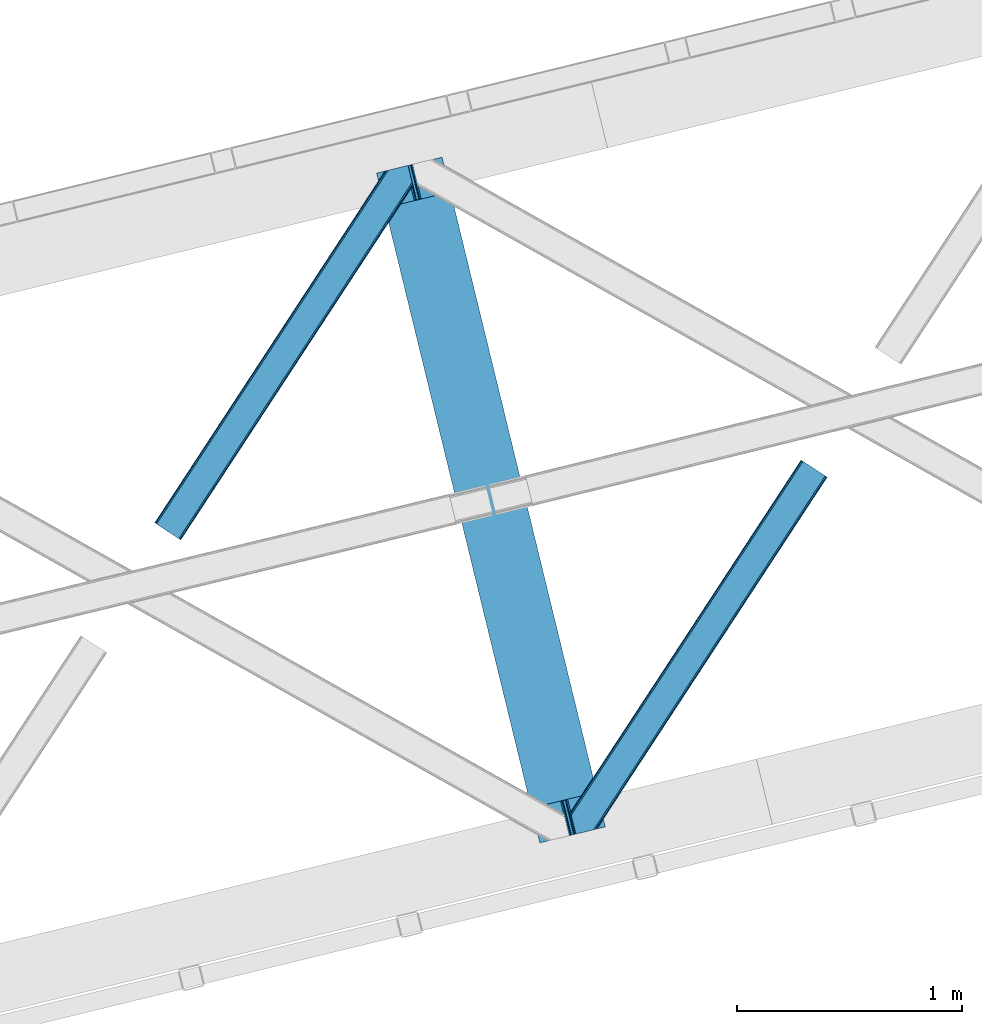
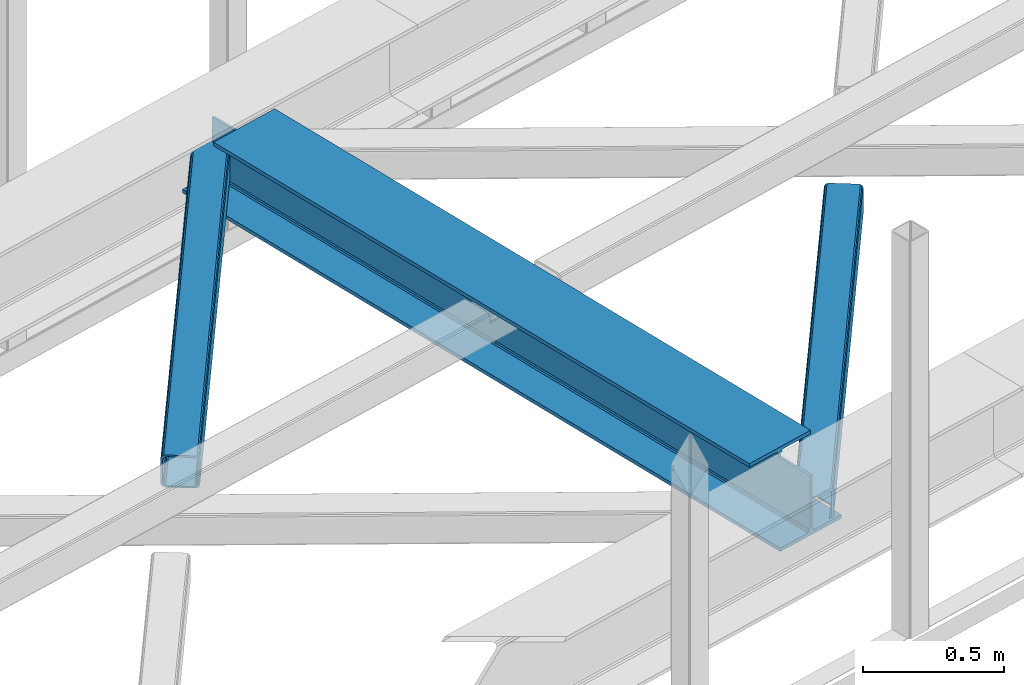
# One storey, part 29 of 67: 2 members, 1 beam.
"""IFC4 building model written with IfcOpenShell, lengths in millimetres."""

from ifc_helpers import new_model, entity, si_unit, converted_unit, derived_unit, direction, frame, origin, place, context, subcontext, project, spatial, triangles, polygons, material, type_object, element, save


model = new_model("IFC4")

# Units and contexts
model_context = context("Model", 3, precision=0.01, world=origin(), true_north=direction((6.12303176911189e-17, 1.0)))
plan_context = context("Plan", 3, precision=0.01, world=origin(), true_north=direction((6.12303176911189e-17, 1.0)))
body_context = subcontext(model_context, "Body", "Model", "MODEL_VIEW")
ifc_project = project(units=[si_unit("LENGTHUNIT", "METRE", prefix="MILLI"), si_unit("AREAUNIT", "SQUARE_METRE"), si_unit("VOLUMEUNIT", "CUBIC_METRE"), converted_unit("PLANEANGLEUNIT", "DEGREE", entity("IfcRatioMeasure", 0.0174532925199433), si_unit("PLANEANGLEUNIT", "RADIAN"), dimensions=[0, 0, 0, 0, 0, 0, 0]), si_unit("MASSUNIT", "GRAM", prefix="KILO"), derived_unit("MASSDENSITYUNIT", [(si_unit("MASSUNIT", "GRAM", prefix="KILO"), 1), (si_unit("LENGTHUNIT", "METRE"), -3)]), derived_unit("MOMENTOFINERTIAUNIT", [(si_unit("LENGTHUNIT", "METRE"), 4)]), si_unit("TIMEUNIT", "SECOND"), si_unit("FREQUENCYUNIT", "HERTZ"), si_unit("THERMODYNAMICTEMPERATUREUNIT", "DEGREE_CELSIUS"), derived_unit("THERMALTRANSMITTANCEUNIT", [(si_unit("MASSUNIT", "GRAM", prefix="KILO"), 1), (si_unit("THERMODYNAMICTEMPERATUREUNIT", "KELVIN"), -1), (si_unit("TIMEUNIT", "SECOND"), -3)]), derived_unit("VOLUMETRICFLOWRATEUNIT", [(si_unit("LENGTHUNIT", "METRE"), 3), (si_unit("TIMEUNIT", "SECOND"), -1)]), derived_unit("MASSFLOWRATEUNIT", [(si_unit("MASSUNIT", "GRAM", prefix="KILO"), 1), (si_unit("TIMEUNIT", "SECOND"), -1)]), derived_unit("ROTATIONALFREQUENCYUNIT", [(si_unit("TIMEUNIT", "SECOND"), -1)]), si_unit("ELECTRICCURRENTUNIT", "AMPERE"), si_unit("ELECTRICVOLTAGEUNIT", "VOLT"), si_unit("POWERUNIT", "WATT"), si_unit("FORCEUNIT", "NEWTON", prefix="KILO"), si_unit("ILLUMINANCEUNIT", "LUX"), si_unit("LUMINOUSFLUXUNIT", "LUMEN"), si_unit("LUMINOUSINTENSITYUNIT", "CANDELA"), derived_unit("USERDEFINED", [(si_unit("MASSUNIT", "GRAM", prefix="KILO"), -1), (si_unit("LENGTHUNIT", "METRE"), -2), (si_unit("TIMEUNIT", "SECOND"), 3), (si_unit("LUMINOUSFLUXUNIT", "LUMEN"), 1)]), derived_unit("LINEARVELOCITYUNIT", [(si_unit("LENGTHUNIT", "METRE"), 1), (si_unit("TIMEUNIT", "SECOND"), -1)]), si_unit("PRESSUREUNIT", "PASCAL"), derived_unit("USERDEFINED", [(si_unit("LENGTHUNIT", "METRE"), -2), (si_unit("MASSUNIT", "GRAM", prefix="KILO"), 1), (si_unit("TIMEUNIT", "SECOND"), -2)]), derived_unit("LINEARFORCEUNIT", [(si_unit("MASSUNIT", "GRAM", prefix="KILO"), 1), (si_unit("LENGTHUNIT", "METRE"), 1), (si_unit("TIMEUNIT", "SECOND"), -2), (si_unit("LENGTHUNIT", "METRE"), -1)]), derived_unit("PLANARFORCEUNIT", [(si_unit("MASSUNIT", "GRAM", prefix="KILO"), 1), (si_unit("LENGTHUNIT", "METRE"), 1), (si_unit("TIMEUNIT", "SECOND"), -2), (si_unit("LENGTHUNIT", "METRE"), -2)])], contexts=[model_context, plan_context])

# Site, building, storey
site_placement = place(None, origin())
site = spatial("IfcSite", under=ifc_project, at=site_placement, CompositionType="ELEMENT")
building_placement = place(site_placement, origin())
building = spatial("IfcBuilding", under=site, at=building_placement, CompositionType="ELEMENT")
storey_placement = place(building_placement, frame((0.0, 0.0, 19800.0)))
storey = spatial("IfcBuildingStorey", under=building, at=storey_placement, CompositionType="ELEMENT", Elevation=19800.0)

# Beam
ifc_material = material(Name="Metal painted (White)")
beam_type = type_object("IfcBeamType", PredefinedType="BEAM")
beam_placement = place(storey_placement, frame((-43080.9339433779, 7293.4957766484, 3808.0)))
element("IfcBeam", 1, at=beam_placement, inside=storey, type_object=beam_type, material=ifc_material, ObjectType="Steel Beam", PredefinedType="BEAM", context=body_context, shape_type="Tessellation", body=[
    polygons([(1018.1664837833, 71.047827897101, 15.5000000000051), (1018.1664837833, 71.0478278971021, 0.0), (291.465617442446, 3052.25531830421, 0.0), (291.465617442455, 3052.25531830421, 15.5000000000051), (894.779372399338, 40.9709140873291, 15.5000000000051), (168.078506058482, 3022.17840449444, 15.5000000000051), (888.087028625366, 39.3395844888243, 16.8701684148028), (161.38616228452, 3020.54707489594, 16.8701684148028), (882.413533524751, 37.956610033653, 20.7720779386478), (155.712667183904, 3019.16410044076, 20.7720779386478), (878.622625296176, 37.0325360459184, 26.6116982174338), (151.921758955329, 3018.24002645303, 26.6116982174338), (877.291435352788, 36.7080444135018, 33.500000000001), (150.590569011924, 3017.91553482062, 33.500000000001), (140.875048430514, 3015.54727389071, 33.500000000001), (140.875048430522, 3015.54727389071, 259.000000000006), (150.590569011924, 3017.91553482061, 259.000000000006), (0.0, 2981.20749040711, 4.33146851719357e-12), (0.0, 2981.20749040711, 15.5000000000051), (123.387111383972, 3011.28440421688, 15.5000000000051), (130.079455157918, 3012.91573381539, 16.8701684148028), (135.752950258542, 3014.29870827056, 20.7720779386478), (139.543858487117, 3015.2227822583, 26.6116982174338), (877.291435352779, 36.7080444135018, 259.000000000006), (867.575914771369, 34.3397834835981, 259.000000000006), (867.575914771369, 34.3397834835981, 33.500000000001), (866.244724827972, 34.0152918511837, 26.6116982174338), (862.453816599406, 33.0912178634492, 20.7720779386478), (856.780321498782, 31.7082434082778, 16.8701684148028), (850.087977724819, 30.076913809773, 15.5000000000051), (726.700866340864, 0.0, 15.5000000000051), (726.700866340864, 0.0, 4.33146851719357e-12), (839.723099725414, 190.827961666225, 259.069792599954), (188.068298227647, 2864.16742161973, 259.000000000006), (188.291691329497, 2863.25097721476, 259.617303331129), (188.304080173122, 2863.20015298098, 266.500003008253), (839.577920935824, 191.42343960925, 266.500002998871), (839.578271056576, 191.422003304514, 260.000004007593), (830.098162489501, 188.087889491627, 259.00634317046), (829.874792453805, 189.004341089457, 259.617303331129), (829.862403610162, 189.055165323231, 266.500003008253), (178.588562847469, 2860.83187869496, 266.500002998871), (178.588212726717, 2860.8333149997, 260.000004007593), (178.443407068381, 2861.42736381349, 259.076120467494), (178.352777646246, 2861.79916068982, 259.000000000006), (840.90940880576, 191.746709053936, 273.388305639792), (844.699685394447, 192.673374225849, 279.227924098781), (850.372756341985, 194.058088689525, 283.129832400619), (857.06494802311, 195.690042220338, 284.500000377228), (980.451976710954, 225.76729527545, 284.500000138975), (980.450306904303, 225.774145344181, 299.999995328161), (688.984884807032, 154.725516080139, 299.999995890966), (688.986554613693, 154.718666011408, 284.500000701776), (812.373583301528, 184.795919066518, 284.500000463524), (819.066070197675, 186.426661533098, 283.129832461069), (824.739981846427, 187.807927177623, 279.227924137327), (828.531516633419, 188.72943082692, 273.388305663689), (177.257074977551, 2860.50860925028, 273.388305639792), (173.466798388846, 2859.58194407836, 279.227924098781), (167.793727441316, 2858.19722961469, 283.129832400619), (161.101535760182, 2856.56527608387, 284.500000377228), (37.7145070723471, 2826.48802302876, 284.500000138975), (37.7161768789988, 2826.48117296003, 299.999995328161), (329.181598976269, 2897.52980222407, 299.999995890962), (329.179929169617, 2897.5366522928, 284.500000701776), (205.792900481765, 2867.45939923769, 284.500000463524), (199.100413585626, 2865.82865677111, 283.129832461069), (193.426501936866, 2864.44739112659, 279.227924137327), (189.634967149874, 2863.52588747729, 273.388305663689)], [[[1, 2, 3, 4]], [[5, 1, 4, 6]], [[7, 5, 6, 8]], [[9, 7, 8, 10]], [[11, 9, 10, 12]], [[13, 11, 12, 14]], [[15, 16, 17, 14, 12, 10, 8, 6, 4, 3, 18, 19, 20, 21, 22, 23]], [[13, 24, 25, 26, 27, 28, 29, 30, 31, 32, 2, 1, 5, 7, 9, 11]], [[2, 32, 18, 3]], [[32, 31, 19, 18]], [[31, 30, 20, 19]], [[27, 26, 15, 23]], [[28, 27, 23, 22]], [[29, 28, 22, 21]], [[30, 29, 21, 20]], [[33, 24, 13, 14, 17, 34, 35, 36, 37, 38]], [[25, 39, 40, 41, 42, 43, 44, 16, 15, 26]], [[39, 25, 24, 33]], [[45, 34, 17, 16]], [[41, 40, 38, 37, 46, 47, 48, 49, 50, 51, 52, 53, 54, 55, 56, 57]], [[42, 58, 59, 60, 61, 62, 63, 64, 65, 66, 67, 68, 69, 36, 35, 43]], [[46, 37, 36, 69]], [[47, 46, 69, 68]], [[48, 47, 68, 67]], [[49, 48, 67, 66]], [[50, 49, 66, 65]], [[51, 50, 65, 64]], [[52, 51, 64, 63]], [[53, 52, 63, 62]], [[54, 53, 62, 61]], [[55, 54, 61, 60]], [[56, 55, 60, 59]], [[57, 56, 59, 58]], [[41, 57, 58, 42]]], closed=False),
])

# Members
member_type_1 = type_object("IfcMemberType", PredefinedType="BRACE")
member_1_placement = place(storey_placement, frame((-44069.1426269531, 8641.4992767334, 3823.99987792968)))
element("IfcMember", 2, at=member_1_placement, inside=storey, type_object=member_type_1, ObjectType="Steel Horizontal Brace", PredefinedType="BRACE", context=body_context, shape_type="Tessellation", body=[
    triangles([(994.771838378911, 1564.02662658691, 0.0), (1028.82092285156, 1424.34794311523, 0.0), (14.6409667968765, 67.1040435791019, 0.0), (102.486767578128, 9.58604278564417, 0.0), (1.1162109375, 75.9604797363281, 10.8039916992202), (0.0, 76.6900863647461, 17.5012573242202), (1025.02580566407, 1642.17883300781, 17.5012573242202), (4.28811035156832, 73.8821182250977, 5.12526855468968), (990.474426269531, 1585.8776184082, 9.49942016601563), (990.041894531256, 1584.44747314453, 8.74132690429906), (989.90701904297, 1583.99168701172, 8.49948120117188), (990.758129882815, 1580.48841247559, 5.12526855468968), (1027.30938720703, 1642.73461303711, 10.8691040039084), (1027.77912597657, 1642.84972229004, 9.49942016601563), (992.599877929693, 1572.93538513184, 1.33247680664135), (9.03665771484521, 70.7724243164066, 1.33247680664135), (1025.02580566407, 1642.17883300781, 122.499499511719), (0.0, 76.6900863647461, 122.499499511719), (1026.92336425782, 1642.64043273926, 129.196765136719), (1.1162109375, 75.9604797363281, 129.196765136719), (1032.31838378907, 1643.95546875, 134.87548828125), (4.28811035156832, 73.8821182250977, 134.87548828125), (1040.39230957031, 1645.92395324707, 138.668280029298), (9.03665771484521, 70.7724243164066, 138.668280029298), (1049.91730957032, 1648.24590454102, 140.00075683594), (14.6409667968765, 67.1040435791019, 140.00075683594), (994.869506835938, 1567.85081176758, 9.49942016601563), (994.75788574219, 1567.00667724609, 9.2947814941399), (994.650915527345, 1566.15091552734, 9.08781738281323), (994.539294433598, 1565.30561828613, 8.8831787109375), (994.74393310547, 1564.14522399902, 8.49948120117188), (1047.05236816406, 1647.54827270508, 9.49942016601563), (14.8921142578183, 66.9377746582031, 8.3320495605476), (20.4964233398496, 63.2693939208984, 6.99957275390625), (997.041467285162, 1554.71440429688, 6.99957275390625), (10.1435668945342, 70.0480499267578, 12.1248413085959), (1042.27126464844, 1646.38322753906, 12.1248413085959), (1036.87624511719, 1645.06702880859, 17.8035644531265), (1034.98333740234, 1644.60542907715, 24.5008300781265), (6.97166748047312, 72.1258300781246, 17.8035644531265), (5.85545654297312, 72.8554367065426, 24.5008300781265), (1026.55129394532, 1433.65900268555, 6.99957275390625), (96.6266601562529, 13.4206924438477, 6.99957275390625), (1028.71860351563, 1424.77698669434, 8.41343994140698), (1032.83463134766, 1407.88615722656, 5.12526855468968), (1033.6857421875, 1404.3817199707, 8.49948120117188), (1030.99288330079, 1415.43918457031, 1.33247680664135), (1034.98333740234, 1644.60542907715, 115.499926757813), (5.85545654297312, 72.8554367065426, 115.499926757813), (1050.3498413086, 1648.35171203613, 131.668707275392), (1059.8748413086, 1650.67250061035, 133.001184082033), (20.4964233398496, 63.2693939208984, 133.001184082033), (14.8921142578183, 66.9377746582031, 131.668707275392), (1042.27126464844, 1646.38322753906, 127.873590087893), (10.1435668945342, 70.0480499267578, 127.873590087893), (1036.87624511719, 1645.06702880859, 122.197192382813), (6.97166748047312, 72.1258300781246, 122.197192382813), (1128.10788574219, 1667.30520629883, 140.00075683594), (1128.10788574219, 1667.30520629883, 133.001184082033), (1144.33015136719, 1600.75810546875, 140.00075683594), (102.486767578128, 9.58604278564417, 140.00075683594), (1142.06052246094, 1610.07032775879, 133.001184082033), (96.6266601562529, 13.4206924438477, 133.001184082033), (1146.50211181641, 1591.84934692383, 138.668280029298), (108.08642578125, 5.91766204833948, 138.668280029298), (1148.33920898438, 1584.29631958008, 134.87548828125), (112.834973144534, 2.80738677978479, 134.87548828125), (1149.57169189453, 1579.2501159668, 129.196765136719), (116.011523437504, 0.729606628417969, 129.196765136719), (1150.00422363282, 1577.47813110351, 122.499499511719), (117.127734375004, 0.0, 122.499499511719), (1150.00422363282, 1577.47813110351, 17.5012573242202), (117.127734375004, 0.0, 17.5012573242202), (106.979516601568, 6.64203643798828, 127.873590087893), (110.156066894531, 4.56425628662146, 122.197192382813), (111.267626953129, 3.83406829833984, 115.499926757813), (102.230969238284, 9.75231170654297, 131.668707275392), (116.011523437504, 0.729606628417969, 10.8039916992202), (106.979516601568, 6.64203643798828, 12.1248413085959), (112.834973144534, 2.80738677978479, 5.12526855468968), (111.267626953129, 3.83406829833984, 24.5008300781265), (110.156066894531, 4.56425628662146, 17.8035644531265), (108.08642578125, 5.91766204833948, 1.33247680664135), (102.230969238284, 9.75231170654297, 8.3320495605476), (1147.30206298828, 1588.56233825684, 122.197192382813), (1147.73459472656, 1586.79035339356, 115.499926757813), (1146.06958007813, 1593.60854187012, 127.873590087893), (1144.23248291016, 1601.16040649414, 131.668707275392), (1147.73459472656, 1586.79035339356, 24.5008300781265), (1147.21369628907, 1588.9239440918, 17.8686767578147), (1149.994921875, 1577.51650085449, 16.5013183593765), (1147.10672607422, 1589.36461486816, 16.5013183593765), (1145.27427978516, 1573.10863037109, 10.8714294433594), (1034.62056884766, 1404.788671875, 9.49942016601563), (1144.12551269532, 1572.03427734375, 9.49942016601563), (1142.79071044922, 1588.59721984863, 12.1248413085959), (1030.22548828126, 1422.8143157959, 9.49942016601563), (1029.19764404297, 1423.6724029541, 8.80643920898365), (1139.73043212891, 1590.05992126465, 9.49942016601563)], [[1, 2, 3], [4, 3, 2], [5, 6, 7], [8, 9, 10], [11, 12, 8], [5, 13, 9], [9, 8, 5], [13, 14, 9], [15, 1, 16], [3, 16, 1], [12, 15, 8], [16, 8, 15], [7, 13, 5], [17, 7, 6], [6, 18, 17], [19, 17, 20], [18, 20, 17], [21, 19, 22], [20, 22, 19], [23, 21, 24], [22, 24, 21], [25, 23, 26], [24, 26, 23], [27, 28, 9], [28, 29, 10], [29, 30, 10], [30, 31, 11], [14, 32, 27], [27, 9, 14], [33, 34, 35], [36, 33, 31], [31, 30, 36], [28, 36, 29], [28, 27, 36], [36, 30, 29], [32, 37, 27], [36, 27, 37], [35, 31, 33], [38, 39, 40], [41, 40, 39], [37, 38, 36], [40, 36, 38], [42, 35, 34], [34, 43, 42], [1, 35, 42], [31, 12, 11], [1, 31, 35], [31, 15, 12], [31, 1, 15], [2, 1, 42], [44, 2, 42], [45, 44, 46], [44, 47, 2], [44, 45, 47], [39, 48, 41], [49, 41, 48], [50, 51, 52], [52, 53, 50], [54, 50, 53], [53, 55, 54], [56, 54, 55], [55, 57, 56], [48, 56, 57], [57, 49, 48], [56, 17, 19], [50, 23, 25], [58, 51, 25], [51, 58, 59], [51, 50, 25], [54, 23, 50], [54, 56, 21], [21, 23, 54], [19, 21, 56], [39, 7, 17], [37, 14, 38], [56, 48, 17], [37, 32, 14], [39, 38, 7], [48, 39, 17], [13, 7, 38], [38, 14, 13], [60, 25, 61], [25, 60, 58], [26, 61, 25], [51, 62, 63], [51, 59, 62], [63, 52, 51], [64, 60, 61], [61, 65, 64], [66, 64, 65], [65, 67, 66], [68, 66, 67], [67, 69, 68], [70, 68, 69], [69, 71, 70], [72, 70, 71], [71, 73, 72], [69, 74, 75], [76, 73, 71], [69, 75, 71], [69, 67, 74], [75, 76, 71], [74, 67, 65], [63, 61, 26], [61, 77, 65], [77, 61, 63], [77, 74, 65], [78, 79, 80], [81, 73, 76], [73, 82, 78], [82, 73, 81], [78, 82, 79], [4, 43, 3], [83, 80, 79], [79, 84, 83], [84, 43, 4], [4, 83, 84], [55, 24, 22], [26, 52, 63], [26, 53, 52], [53, 26, 24], [55, 53, 24], [49, 18, 6], [20, 57, 55], [22, 20, 55], [57, 20, 18], [49, 57, 18], [16, 36, 8], [3, 43, 34], [34, 33, 3], [33, 36, 16], [16, 3, 33], [5, 8, 36], [6, 41, 49], [40, 6, 5], [6, 40, 41], [40, 5, 36], [85, 86, 75], [76, 75, 86], [87, 85, 74], [75, 74, 85], [88, 87, 77], [74, 77, 87], [62, 88, 63], [77, 63, 88], [86, 89, 76], [81, 76, 89], [90, 91, 92], [70, 72, 89], [72, 90, 89], [89, 86, 70], [72, 91, 90], [85, 70, 86], [68, 70, 85], [66, 85, 87], [85, 66, 68], [87, 64, 66], [88, 64, 87], [88, 62, 60], [88, 60, 64], [62, 58, 60], [62, 59, 58], [73, 78, 93], [93, 72, 73], [94, 93, 78], [94, 95, 93], [80, 45, 46], [46, 78, 80], [46, 94, 78], [47, 45, 83], [80, 83, 45], [2, 47, 4], [83, 4, 47], [93, 91, 72], [82, 81, 89], [82, 92, 96], [82, 90, 92], [84, 97, 98], [79, 96, 97], [97, 84, 79], [96, 99, 97], [43, 84, 44], [44, 42, 43], [96, 79, 82], [89, 90, 82], [96, 91, 93], [96, 92, 91], [96, 95, 99], [93, 95, 96], [99, 95, 97], [94, 97, 95]]),
])
member_type_2 = type_object("IfcMemberType", PredefinedType="BRACE")
member_2_placement = place(storey_placement, frame((-42217.8230712891, 7332.57045135498, 3823.99987792968)))
element("IfcMember", 3, at=member_2_placement, inside=storey, type_object=member_type_2, ObjectType="Steel Horizontal Brace", PredefinedType="BRACE", context=body_context, shape_type="Tessellation", body=[
    triangles([(109.770043945311, 259.950411987305, 7.52047119140843), (115.034838867192, 238.366264343262, 7.77626953125218), (114.220935058598, 239.947563171387, 8.3320495605476), (108.811962890628, 259.663220214844, 8.52041015625218), (113.639575195317, 239.860359191895, 8.52041015625218), (112.211755371092, 237.678515625, 8.52041015625218), (91.0363037109419, 232.517202758789, 8.52041015625218), (109.537499999999, 237.026229858398, 9.49942016601563), (90.2642578125015, 232.328842163086, 9.49942016601563), (5.02294921875, 77.405158996582, 9.49942016601563), (0.62786865234375, 95.4313842773436, 9.49942016601563), (1046.62448730469, 1651.75382995605, 6.99957275390625), (1041.02482910157, 1655.42279205322, 8.3320495605476), (116.704504394533, 231.514938354492, 6.99957275390625), (1036.27163085937, 1658.53248596191, 12.1248413085959), (3.93464355469041, 81.8758163452148, 12.1248413085959), (1033.09973144531, 1660.61084747314, 17.8035644531265), (2.70216064453416, 86.9220199584961, 17.8035644531265), (1031.98352050781, 1661.3398727417, 24.5008300781265), (2.26962890625146, 88.6945861816403, 24.5008300781265), (1122.759375, 1601.905128479, 6.99957275390625), (146.20968017578, 110.459536743164, 6.99957275390625), (1031.98352050781, 1661.3398727417, 115.499926757813), (2.26962890625146, 88.6945861816403, 115.499926757813), (1033.09973144531, 1660.61084747314, 122.197192382813), (2.70216064453416, 86.9220199584961, 122.197192382813), (1036.27163085937, 1658.53248596191, 127.873590087893), (3.93464355469041, 81.8758163452148, 127.873590087893), (1041.02482910157, 1655.42279205322, 131.668707275392), (5.77174072265916, 74.3233703613278, 131.668707275392), (1046.62448730469, 1651.75382995605, 133.001184082033), (7.94370117187646, 65.4146118164063, 133.001184082033), (1027.24427490235, 1664.44491577148, 10.8039916992202), (0.520898437498545, 95.8720550537109, 10.8691040039084), (0.0, 98.0062271118168, 17.5012573242202), (1035.16472167969, 1659.25686035156, 1.33247680664135), (112.262915039064, 249.735919189453, 1.33247680664135), (110.546740722661, 256.77269897461, 5.59500732422021), (109.077062988283, 259.839953613281, 8.32042236328198), (1030.41617431641, 1662.36713562012, 5.12526855468968), (1040.76903076172, 1655.58847961426, 0.0), (114.434875488281, 240.827160644531, 0.0), (1026.12806396485, 1665.1745223999, 17.5012573242202), (1128.61483154297, 1598.07106018066, 0.0), (148.479309082031, 101.147895812988, 0.0), (150.651269531249, 92.2391372680668, 1.33247680664135), (148.511865234374, 101.029879760742, 8.49948120117188), (152.493017578126, 84.6866912841797, 5.12526855468968), (153.348779296874, 81.1828353881838, 8.49948120117188), (1026.12806396485, 1665.1745223999, 122.499499511719), (0.0, 98.0062271118168, 122.499499511719), (1040.76903076172, 1655.58847961426, 140.00075683594), (1035.16472167969, 1659.25686035156, 138.668280029298), (3.50211181640771, 83.6350112915043, 138.668280029298), (5.674072265625, 74.7262527465818, 140.00075683594), (1030.41617431641, 1662.36713562012, 134.87548828125), (1.66501464843896, 91.1874572753904, 134.87548828125), (1027.24427490235, 1664.44491577148, 129.196765136719), (0.432531738282705, 96.2342422485353, 129.196765136719), (23.8915649414048, 0.0, 140.00075683594), (23.8915649414048, 0.0, 133.001184082033), (1128.61483154297, 1598.07106018066, 140.00075683594), (93.3384887695356, 16.9286178588864, 140.00075683594), (1122.759375, 1601.905128479, 133.001184082033), (83.3809570312515, 14.5014404296871, 133.001184082033), (1143.25579833984, 1588.48443603516, 122.499499511719), (1142.13958740234, 1589.21404266357, 129.196765136719), (118.225341796875, 22.9956893920898, 122.499499511719), (116.332434082033, 22.5340896606449, 129.196765136719), (1138.96768798828, 1591.2924041748, 134.87548828125), (110.937414550783, 21.219053649902, 134.87548828125), (1134.2144897461, 1594.4020980835, 138.668280029298), (102.86348876953, 19.2505691528322, 138.668280029298), (1143.25579833984, 1588.48443603516, 17.5012573242202), (118.225341796875, 22.9956893920898, 17.5012573242202), (1142.13958740234, 1589.21404266357, 10.8039916992202), (1133.11223144532, 1595.12705383301, 12.1248413085959), (1136.28413085938, 1593.04869232178, 17.8035644531265), (1137.40034179688, 1592.31908569336, 24.5008300781265), (1138.96768798828, 1591.2924041748, 5.12526855468968), (1134.2144897461, 1594.4020980835, 1.33247680664135), (1128.35903320312, 1598.2367477417, 8.3320495605476), (1133.11223144532, 1595.12705383301, 127.873590087893), (1137.40034179688, 1592.31908569336, 115.499926757813), (1136.28413085938, 1593.04869232178, 122.197192382813), (1128.35903320312, 1598.2367477417, 131.668707275392), (92.9059570312529, 16.823391723633, 131.668707275392), (100.979882812499, 18.7918762207028, 127.873590087893), (106.374902343749, 20.1069122314457, 122.197192382813), (108.2724609375, 20.5690933227543, 115.499926757813), (108.2724609375, 20.5690933227543, 24.5008300781265), (100.979882812499, 18.7918762207028, 12.1248413085959), (115.472021484376, 22.3248001098636, 9.49942016601563), (106.374902343749, 20.1069122314457, 17.8035644531265), (96.2034301757813, 17.6268310546875, 9.49942016601563), (115.946411132813, 22.4393280029299, 10.8691040039084), (153.065075683597, 80.2398696899418, 8.99945068359375), (152.776721191411, 79.2974853515625, 9.49942016601563), (148.711853027344, 99.8683227539059, 8.8831787109375), (148.604882812499, 99.0241882324217, 9.08781738281323), (148.493261718751, 98.1678451538082, 9.2947814941399), (148.386291503906, 97.3231292724613, 9.49942016601563)], [[1, 2, 3], [4, 5, 6], [6, 7, 4], [7, 6, 8], [8, 9, 7], [9, 8, 10], [10, 11, 9], [12, 13, 3], [3, 2, 12], [2, 14, 12], [15, 16, 8], [8, 13, 15], [8, 5, 13], [16, 10, 8], [8, 6, 5], [15, 17, 18], [18, 16, 15], [17, 19, 20], [20, 18, 17], [21, 12, 14], [14, 22, 21], [19, 23, 24], [24, 20, 19], [23, 25, 24], [26, 24, 25], [25, 27, 26], [28, 26, 27], [27, 29, 28], [30, 28, 29], [29, 31, 30], [32, 30, 31], [33, 34, 35], [36, 37, 38], [33, 4, 9], [33, 1, 39], [9, 34, 33], [9, 11, 34], [4, 7, 9], [40, 38, 1], [1, 33, 40], [38, 40, 36], [36, 41, 37], [42, 37, 41], [35, 43, 33], [41, 44, 42], [45, 42, 44], [14, 42, 22], [37, 2, 38], [2, 37, 42], [38, 2, 1], [42, 14, 2], [22, 42, 45], [46, 47, 45], [47, 46, 48], [45, 47, 22], [48, 49, 47], [50, 43, 35], [35, 51, 50], [52, 53, 54], [54, 55, 52], [53, 56, 57], [57, 54, 53], [56, 58, 59], [59, 57, 56], [58, 50, 51], [51, 59, 58], [28, 57, 26], [30, 32, 55], [32, 60, 55], [32, 61, 60], [54, 30, 55], [28, 54, 57], [16, 11, 10], [28, 30, 54], [51, 35, 20], [24, 26, 51], [24, 51, 20], [57, 59, 26], [26, 59, 51], [35, 18, 20], [18, 11, 16], [11, 18, 34], [35, 34, 18], [62, 55, 63], [62, 52, 55], [55, 60, 63], [64, 32, 31], [32, 64, 65], [61, 32, 65], [66, 67, 68], [69, 68, 67], [67, 70, 69], [71, 69, 70], [70, 72, 71], [73, 71, 72], [72, 62, 73], [63, 73, 62], [74, 66, 68], [68, 75, 74], [76, 77, 78], [79, 66, 74], [76, 78, 74], [76, 80, 77], [78, 79, 74], [77, 80, 81], [21, 44, 41], [44, 82, 81], [82, 44, 21], [82, 77, 81], [67, 83, 70], [84, 66, 79], [66, 85, 67], [85, 66, 84], [67, 85, 83], [62, 64, 52], [72, 70, 83], [83, 86, 72], [86, 64, 62], [62, 72, 86], [15, 36, 40], [41, 12, 21], [41, 13, 12], [13, 41, 36], [15, 13, 36], [19, 43, 50], [33, 17, 15], [40, 33, 15], [17, 33, 43], [19, 17, 43], [53, 27, 56], [52, 64, 31], [31, 29, 52], [29, 27, 53], [53, 52, 29], [58, 56, 27], [50, 23, 19], [25, 50, 58], [50, 25, 23], [25, 58, 27], [64, 86, 87], [87, 65, 64], [86, 83, 88], [88, 87, 86], [83, 85, 89], [89, 88, 83], [85, 84, 90], [90, 89, 85], [84, 79, 91], [91, 90, 84], [89, 68, 69], [87, 73, 63], [60, 65, 63], [65, 60, 61], [65, 87, 63], [88, 73, 87], [88, 89, 71], [71, 73, 88], [69, 71, 89], [91, 75, 68], [92, 93, 94], [89, 90, 68], [92, 95, 93], [91, 94, 75], [90, 91, 68], [96, 75, 94], [94, 93, 96], [76, 74, 75], [49, 80, 97], [98, 97, 80], [49, 48, 80], [76, 96, 98], [98, 80, 76], [96, 93, 98], [44, 81, 45], [46, 45, 81], [81, 80, 46], [48, 46, 80], [75, 96, 76], [82, 21, 22], [77, 82, 47], [47, 99, 77], [77, 100, 101], [100, 77, 99], [101, 102, 77], [77, 102, 92], [95, 92, 102], [22, 47, 82], [79, 78, 91], [94, 91, 78], [78, 77, 94], [92, 94, 77], [102, 101, 98], [101, 100, 97], [100, 99, 49], [99, 47, 49], [102, 98, 93], [93, 95, 102]]),
])

save(model, "model.ifc")
